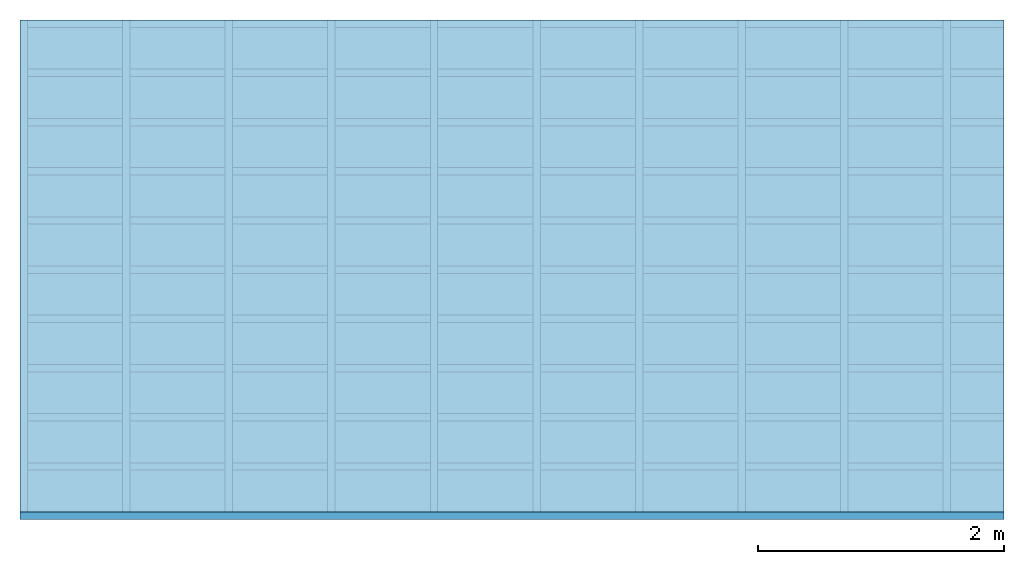
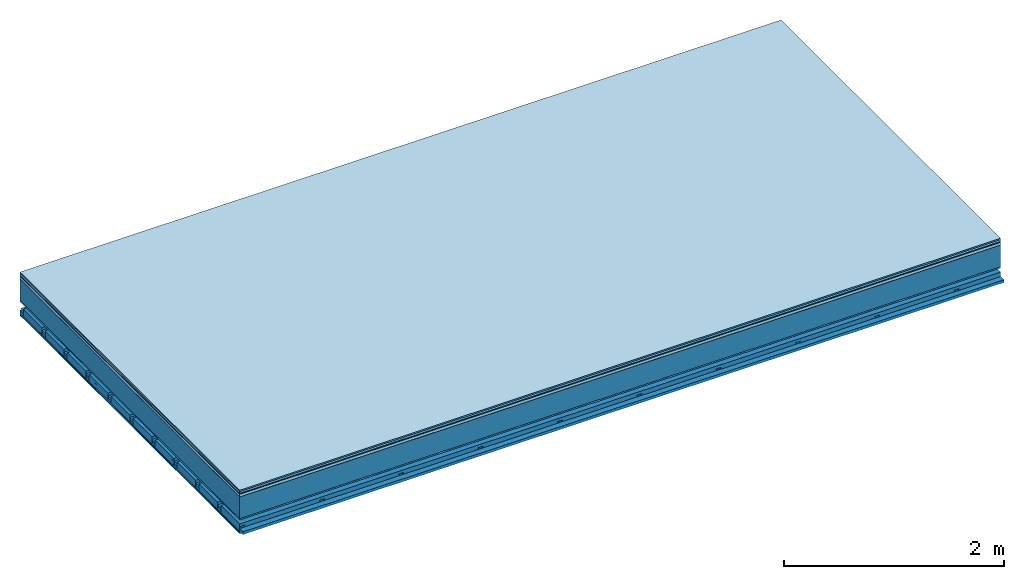
# One storey: 9 plates, 4 members, 1 element without a shape of its own.
"""IFC4 building model written with IfcOpenShell, lengths in metres."""

from ifc_helpers import new_model, si_unit, derived_unit, direction, frame, frame_2d, origin, origin_with_axes, place, context, project, spatial, polyline, rectangle, outline, extrude, material, layer, layer_set, type_object, element, aggregate, save


model = new_model("IFC4")

# Units and contexts
plan_context = context("Plan", 3, precision=1e-05, world=origin(), true_north=direction((0.0, 1.0)))
model_context = context("Model", 3, precision=1e-05, world=origin(), true_north=direction((0.0, 1.0)))
ifc_project = project(units=[si_unit("LENGTHUNIT", "METRE"), derived_unit("SOUNDPRESSUREUNIT", [(si_unit("PRESSUREUNIT", "PASCAL", prefix="MICRO"), 0)]), si_unit("ENERGYUNIT", "JOULE", prefix="MEGA"), si_unit("MASSUNIT", "GRAM", prefix="KILO"), derived_unit("THERMALTRANSMITTANCEUNIT", [(si_unit("POWERUNIT", "WATT"), 1), (si_unit("AREAUNIT", "SQUARE_METRE"), -1), (si_unit("THERMODYNAMICTEMPERATUREUNIT", "KELVIN"), -1)]), derived_unit("AREADENSITYUNIT", [(si_unit("MASSUNIT", "GRAM", prefix="KILO"), 1), (si_unit("AREAUNIT", "SQUARE_METRE"), -1)]), derived_unit("USERDEFINED", [(si_unit("ENERGYUNIT", "JOULE", prefix="MEGA"), 1), (si_unit("AREAUNIT", "SQUARE_METRE"), -1)])], contexts=[plan_context, model_context])

# Site, building, storey
site = spatial("IfcSite", under=ifc_project)
building_placement = place(None, origin())
building = spatial("IfcBuilding", under=site, at=building_placement)
storey_placement = place(building_placement, origin())
storey = spatial("IfcBuildingStorey", under=building, at=storey_placement)

# Slab, members, plates
ifc_material_1 = material(Category="11.013")
ifc_layer_1 = layer(ifc_material_1, 0.015, Name="Flooring")
ifc_material_2 = material(Category="03.007")
ifc_layer_2 = layer(ifc_material_2, 0.02, Name="On-material")
ifc_material_3 = material(Name="Wood fiber generic product", Category="10.009")
ifc_layer_3 = layer(ifc_material_3, 0.01, Name="Impact sound insulation")
ifc_material_4 = material(Name="with broken")
ifc_layer_4 = layer(ifc_material_4, 0.03, Name="on Supporting structure")
ifc_material_5 = material(Name="protection", Category="09.007")
ifc_layer_5 = layer(ifc_material_5, 0.0005, Name="Sub-floor")
ifc_material_6 = material(Name="no composite action")
ifc_layer_6 = layer(ifc_material_6, 0.0, Name="Bond")
ifc_layer_7 = layer(None, 0.24, Name="Supporting structure")
ifc_material_7 = material(Name="of the art")
ifc_layer_8 = layer(ifc_material_7, 0.0, Name="Bond")
ifc_layer_9 = layer(ifc_material_2, 0.015, Name="Lower layer 1")
ifc_layer_10 = layer(None, 0.095, Name="Coupling")
ifc_layer_11 = layer(None, 0.03, Name="Battens / profiles")
ifc_material_8 = material(Name="Plasterboard type A", Category="03.008")
ifc_layer_12 = layer(ifc_material_8, 0.0125, Name="Ceiling covering 1st layer")
ifc_layer_13 = layer(ifc_material_8, 0.0125, Name="Ceiling covering layer 2")
ifc_material_9 = material(Category="04.001")
ifc_layer_14 = layer(ifc_material_9, 0.003, Name="Surface / treatment")
ifc_layer_set = layer_set([ifc_layer_1, ifc_layer_2, ifc_layer_3, ifc_layer_4, ifc_layer_5, ifc_layer_6, ifc_layer_7, ifc_layer_8, ifc_layer_9, ifc_layer_10, ifc_layer_11, ifc_layer_12, ifc_layer_13, ifc_layer_14])
slab_type = type_object("IfcSlabType", Name="A2129", PredefinedType="NOTDEFINED", material=ifc_layer_set)
slab_placement = place(None, frame((0.0, 0.0, 0.0), z_axis=(0.0, 0.0, -1.0), x_axis=(1.0, 0.0, 0.0)))
slab = element("IfcSlab", 1, at=slab_placement, inside=storey, type_object=slab_type, material=ifc_layer_set, Name="Slab #1")
ifc_material_10 = material(Name="Solid timber panel")
member_1_placement = place(slab_placement, origin())
member_1 = element("IfcMember", 2, at=member_1_placement, material=ifc_material_10, Name="Supporting structure", context=plan_context, shape_type="SweptSolid", body=[
    extrude(rectangle(XDim=1.0, YDim=0.24, at=frame_2d((0.5, 0.12), x_axis=(1.0, 0.0))), frame((0.0, 4.0, 0.0755), z_axis=(0.0, -1.0, 0.0), x_axis=(1.0, 0.0, 0.0)), (0.0, 0.0, 1.0), 4.0),
    extrude(rectangle(XDim=1.0, YDim=0.24, at=frame_2d((0.5, 0.12), x_axis=(1.0, 0.0))), frame((1.0, 4.0, 0.0755), z_axis=(0.0, -1.0, 0.0), x_axis=(1.0, 0.0, 0.0)), (0.0, 0.0, 1.0), 4.0),
    extrude(rectangle(XDim=1.0, YDim=0.24, at=frame_2d((0.5, 0.12), x_axis=(1.0, 0.0))), frame((2.0, 4.0, 0.0755), z_axis=(0.0, -1.0, 0.0), x_axis=(1.0, 0.0, 0.0)), (0.0, 0.0, 1.0), 4.0),
    extrude(rectangle(XDim=1.0, YDim=0.24, at=frame_2d((0.5, 0.12), x_axis=(1.0, 0.0))), frame((3.0, 4.0, 0.0755), z_axis=(0.0, -1.0, 0.0), x_axis=(1.0, 0.0, 0.0)), (0.0, 0.0, 1.0), 4.0),
    extrude(rectangle(XDim=1.0, YDim=0.24, at=frame_2d((0.5, 0.12), x_axis=(1.0, 0.0))), frame((4.0, 4.0, 0.0755), z_axis=(0.0, -1.0, 0.0), x_axis=(1.0, 0.0, 0.0)), (0.0, 0.0, 1.0), 4.0),
    extrude(rectangle(XDim=1.0, YDim=0.24, at=frame_2d((0.5, 0.12), x_axis=(1.0, 0.0))), frame((5.0, 4.0, 0.0755), z_axis=(0.0, -1.0, 0.0), x_axis=(1.0, 0.0, 0.0)), (0.0, 0.0, 1.0), 4.0),
    extrude(rectangle(XDim=1.0, YDim=0.24, at=frame_2d((0.5, 0.12), x_axis=(1.0, 0.0))), frame((6.0, 4.0, 0.0755), z_axis=(0.0, -1.0, 0.0), x_axis=(1.0, 0.0, 0.0)), (0.0, 0.0, 1.0), 4.0),
    extrude(rectangle(XDim=1.0, YDim=0.24, at=frame_2d((0.5, 0.12), x_axis=(1.0, 0.0))), frame((7.0, 4.0, 0.0755), z_axis=(0.0, -1.0, 0.0), x_axis=(1.0, 0.0, 0.0)), (0.0, 0.0, 1.0), 4.0),
])
ifc_material_11 = material()
member_2_placement = place(slab_placement, origin())
member_2 = element("IfcMember", 3, at=member_2_placement, material=ifc_material_11, Name="Coupling", context=plan_context, shape_type="SweptSolid", body=[
    extrude(outline(polyline([(0.0, 0.0), (0.06, 0.0), (0.04, 0.02), (0.02, 0.02), (0.0, 0.0)])), frame((0.0, 4.0, 0.4055), z_axis=(0.0, -1.0, 0.0), x_axis=(1.0, 0.0, 0.0)), (0.0, 0.0, 1.0), 4.0),
    extrude(outline(polyline([(0.0, 0.0), (0.06, 0.0), (0.04, 0.02), (0.02, 0.02), (0.0, 0.0)])), frame((0.834, 4.0, 0.4055), z_axis=(0.0, -1.0, 0.0), x_axis=(1.0, 0.0, 0.0)), (0.0, 0.0, 1.0), 4.0),
    extrude(outline(polyline([(0.0, 0.0), (0.06, 0.0), (0.04, 0.02), (0.02, 0.02), (0.0, 0.0)])), frame((1.668, 4.0, 0.4055), z_axis=(0.0, -1.0, 0.0), x_axis=(1.0, 0.0, 0.0)), (0.0, 0.0, 1.0), 4.0),
    extrude(outline(polyline([(0.0, 0.0), (0.06, 0.0), (0.04, 0.02), (0.02, 0.02), (0.0, 0.0)])), frame((2.502, 4.0, 0.4055), z_axis=(0.0, -1.0, 0.0), x_axis=(1.0, 0.0, 0.0)), (0.0, 0.0, 1.0), 4.0),
    extrude(outline(polyline([(0.0, 0.0), (0.06, 0.0), (0.04, 0.02), (0.02, 0.02), (0.0, 0.0)])), frame((3.336, 4.0, 0.4055), z_axis=(0.0, -1.0, 0.0), x_axis=(1.0, 0.0, 0.0)), (0.0, 0.0, 1.0), 4.0),
    extrude(outline(polyline([(0.0, 0.0), (0.06, 0.0), (0.04, 0.02), (0.02, 0.02), (0.0, 0.0)])), frame((4.17, 4.0, 0.4055), z_axis=(0.0, -1.0, 0.0), x_axis=(1.0, 0.0, 0.0)), (0.0, 0.0, 1.0), 4.0),
    extrude(outline(polyline([(0.0, 0.0), (0.06, 0.0), (0.04, 0.02), (0.02, 0.02), (0.0, 0.0)])), frame((5.004, 4.0, 0.4055), z_axis=(0.0, -1.0, 0.0), x_axis=(1.0, 0.0, 0.0)), (0.0, 0.0, 1.0), 4.0),
    extrude(outline(polyline([(0.0, 0.0), (0.06, 0.0), (0.04, 0.02), (0.02, 0.02), (0.0, 0.0)])), frame((5.838, 4.0, 0.4055), z_axis=(0.0, -1.0, 0.0), x_axis=(1.0, 0.0, 0.0)), (0.0, 0.0, 1.0), 4.0),
    extrude(outline(polyline([(0.0, 0.0), (0.06, 0.0), (0.04, 0.02), (0.02, 0.02), (0.0, 0.0)])), frame((6.672, 4.0, 0.4055), z_axis=(0.0, -1.0, 0.0), x_axis=(1.0, 0.0, 0.0)), (0.0, 0.0, 1.0), 4.0),
    extrude(outline(polyline([(0.0, 0.0), (0.06, 0.0), (0.04, 0.02), (0.02, 0.02), (0.0, 0.0)])), frame((7.506, 4.0, 0.4055), z_axis=(0.0, -1.0, 0.0), x_axis=(1.0, 0.0, 0.0)), (0.0, 0.0, 1.0), 4.0),
])
member_3_placement = place(slab_placement, origin())
member_3 = element("IfcMember", 4, at=member_3_placement, material=ifc_material_11, Name="Battens / profiles", context=plan_context, shape_type="SweptSolid", body=[
    extrude(rectangle(XDim=0.06, YDim=0.03, at=frame_2d((0.03, 0.015), x_axis=(1.0, 0.0))), frame((0.0, 0.0, 0.4255), z_axis=(1.0, 0.0, 0.0), x_axis=(0.0, 1.0, 0.0)), (0.0, 0.0, 1.0), 8.0),
    extrude(rectangle(XDim=0.06, YDim=0.03, at=frame_2d((0.03, 0.015), x_axis=(1.0, 0.0))), frame((0.0, 0.4, 0.4255), z_axis=(1.0, 0.0, 0.0), x_axis=(0.0, 1.0, 0.0)), (0.0, 0.0, 1.0), 8.0),
    extrude(rectangle(XDim=0.06, YDim=0.03, at=frame_2d((0.03, 0.015), x_axis=(1.0, 0.0))), frame((0.0, 0.8, 0.4255), z_axis=(1.0, 0.0, 0.0), x_axis=(0.0, 1.0, 0.0)), (0.0, 0.0, 1.0), 8.0),
    extrude(rectangle(XDim=0.06, YDim=0.03, at=frame_2d((0.03, 0.015), x_axis=(1.0, 0.0))), frame((0.0, 1.2, 0.4255), z_axis=(1.0, 0.0, 0.0), x_axis=(0.0, 1.0, 0.0)), (0.0, 0.0, 1.0), 8.0),
    extrude(rectangle(XDim=0.06, YDim=0.03, at=frame_2d((0.03, 0.015), x_axis=(1.0, 0.0))), frame((0.0, 1.6, 0.4255), z_axis=(1.0, 0.0, 0.0), x_axis=(0.0, 1.0, 0.0)), (0.0, 0.0, 1.0), 8.0),
    extrude(rectangle(XDim=0.06, YDim=0.03, at=frame_2d((0.03, 0.015), x_axis=(1.0, 0.0))), frame((0.0, 2.0, 0.4255), z_axis=(1.0, 0.0, 0.0), x_axis=(0.0, 1.0, 0.0)), (0.0, 0.0, 1.0), 8.0),
    extrude(rectangle(XDim=0.06, YDim=0.03, at=frame_2d((0.03, 0.015), x_axis=(1.0, 0.0))), frame((0.0, 2.4, 0.4255), z_axis=(1.0, 0.0, 0.0), x_axis=(0.0, 1.0, 0.0)), (0.0, 0.0, 1.0), 8.0),
    extrude(rectangle(XDim=0.06, YDim=0.03, at=frame_2d((0.03, 0.015), x_axis=(1.0, 0.0))), frame((0.0, 2.8, 0.4255), z_axis=(1.0, 0.0, 0.0), x_axis=(0.0, 1.0, 0.0)), (0.0, 0.0, 1.0), 8.0),
    extrude(rectangle(XDim=0.06, YDim=0.03, at=frame_2d((0.03, 0.015), x_axis=(1.0, 0.0))), frame((0.0, 3.2, 0.4255), z_axis=(1.0, 0.0, 0.0), x_axis=(0.0, 1.0, 0.0)), (0.0, 0.0, 1.0), 8.0),
    extrude(rectangle(XDim=0.06, YDim=0.03, at=frame_2d((0.03, 0.015), x_axis=(1.0, 0.0))), frame((0.0, 3.6, 0.4255), z_axis=(1.0, 0.0, 0.0), x_axis=(0.0, 1.0, 0.0)), (0.0, 0.0, 1.0), 8.0),
    extrude(rectangle(XDim=0.06, YDim=0.03, at=frame_2d((0.03, 0.015), x_axis=(1.0, 0.0))), frame((0.0, 4.0, 0.4255), z_axis=(1.0, 0.0, 0.0), x_axis=(0.0, 1.0, 0.0)), (0.0, 0.0, 1.0), 8.0),
])
ifc_material_12 = material()
member_4_placement = place(slab_placement, origin())
member_4 = element("IfcMember", 5, at=member_4_placement, material=ifc_material_12, Name="Cavity", context=plan_context, shape_type="SweptSolid", body=[
    extrude(rectangle(XDim=0.34, YDim=0.08, at=frame_2d((0.17, 0.04), x_axis=(1.0, 0.0))), frame((0.0, 0.06, 0.3755), z_axis=(1.0, 0.0, 0.0), x_axis=(0.0, 1.0, 0.0)), (0.0, 0.0, 1.0), 8.0),
    extrude(rectangle(XDim=0.34, YDim=0.08, at=frame_2d((0.17, 0.04), x_axis=(1.0, 0.0))), frame((0.0, 0.46, 0.3755), z_axis=(1.0, 0.0, 0.0), x_axis=(0.0, 1.0, 0.0)), (0.0, 0.0, 1.0), 8.0),
    extrude(rectangle(XDim=0.34, YDim=0.08, at=frame_2d((0.17, 0.04), x_axis=(1.0, 0.0))), frame((0.0, 0.86, 0.3755), z_axis=(1.0, 0.0, 0.0), x_axis=(0.0, 1.0, 0.0)), (0.0, 0.0, 1.0), 8.0),
    extrude(rectangle(XDim=0.34, YDim=0.08, at=frame_2d((0.17, 0.04), x_axis=(1.0, 0.0))), frame((0.0, 1.26, 0.3755), z_axis=(1.0, 0.0, 0.0), x_axis=(0.0, 1.0, 0.0)), (0.0, 0.0, 1.0), 8.0),
    extrude(rectangle(XDim=0.34, YDim=0.08, at=frame_2d((0.17, 0.04), x_axis=(1.0, 0.0))), frame((0.0, 1.66, 0.3755), z_axis=(1.0, 0.0, 0.0), x_axis=(0.0, 1.0, 0.0)), (0.0, 0.0, 1.0), 8.0),
    extrude(rectangle(XDim=0.34, YDim=0.08, at=frame_2d((0.17, 0.04), x_axis=(1.0, 0.0))), frame((0.0, 2.06, 0.3755), z_axis=(1.0, 0.0, 0.0), x_axis=(0.0, 1.0, 0.0)), (0.0, 0.0, 1.0), 8.0),
    extrude(rectangle(XDim=0.34, YDim=0.08, at=frame_2d((0.17, 0.04), x_axis=(1.0, 0.0))), frame((0.0, 2.46, 0.3755), z_axis=(1.0, 0.0, 0.0), x_axis=(0.0, 1.0, 0.0)), (0.0, 0.0, 1.0), 8.0),
    extrude(rectangle(XDim=0.34, YDim=0.08, at=frame_2d((0.17, 0.04), x_axis=(1.0, 0.0))), frame((0.0, 2.86, 0.3755), z_axis=(1.0, 0.0, 0.0), x_axis=(0.0, 1.0, 0.0)), (0.0, 0.0, 1.0), 8.0),
    extrude(rectangle(XDim=0.34, YDim=0.08, at=frame_2d((0.17, 0.04), x_axis=(1.0, 0.0))), frame((0.0, 3.26, 0.3755), z_axis=(1.0, 0.0, 0.0), x_axis=(0.0, 1.0, 0.0)), (0.0, 0.0, 1.0), 8.0),
    extrude(rectangle(XDim=0.34, YDim=0.08, at=frame_2d((0.17, 0.04), x_axis=(1.0, 0.0))), frame((0.0, 3.66, 0.3755), z_axis=(1.0, 0.0, 0.0), x_axis=(0.0, 1.0, 0.0)), (0.0, 0.0, 1.0), 8.0),
])
plate_1_placement = place(slab_placement, origin())
plate_1 = element("IfcPlate", 6, at=plate_1_placement, material=ifc_material_1, Name="Flooring", context=plan_context, shape_type="SweptSolid", body=[
    extrude(rectangle(XDim=8.0, YDim=4.0, at=frame_2d((4.0, 2.0), x_axis=(1.0, 0.0))), origin_with_axes(), (0.0, 0.0, 1.0), 0.015),
])
plate_2_placement = place(slab_placement, origin())
plate_2 = element("IfcPlate", 7, at=plate_2_placement, material=ifc_material_2, Name="On-material", context=plan_context, shape_type="SweptSolid", body=[
    extrude(rectangle(XDim=8.0, YDim=4.0, at=frame_2d((4.0, 2.0), x_axis=(1.0, 0.0))), frame((0.0, 0.0, 0.015), z_axis=(0.0, 0.0, 1.0), x_axis=(1.0, 0.0, 0.0)), (0.0, 0.0, 1.0), 0.02),
])
plate_3_placement = place(slab_placement, origin())
plate_3 = element("IfcPlate", 8, at=plate_3_placement, material=ifc_material_3, Name="Impact sound insulation", context=plan_context, shape_type="SweptSolid", body=[
    extrude(rectangle(XDim=8.0, YDim=4.0, at=frame_2d((4.0, 2.0), x_axis=(1.0, 0.0))), frame((0.0, 0.0, 0.035), z_axis=(0.0, 0.0, 1.0), x_axis=(1.0, 0.0, 0.0)), (0.0, 0.0, 1.0), 0.01),
])
plate_4_placement = place(slab_placement, origin())
plate_4 = element("IfcPlate", 9, at=plate_4_placement, material=ifc_material_4, Name="on Supporting structure", context=plan_context, shape_type="SweptSolid", body=[
    extrude(rectangle(XDim=8.0, YDim=4.0, at=frame_2d((4.0, 2.0), x_axis=(1.0, 0.0))), frame((0.0, 0.0, 0.045), z_axis=(0.0, 0.0, 1.0), x_axis=(1.0, 0.0, 0.0)), (0.0, 0.0, 1.0), 0.03),
])
plate_5_placement = place(slab_placement, origin())
plate_5 = element("IfcPlate", 10, at=plate_5_placement, material=ifc_material_5, Name="Sub-floor", context=plan_context, shape_type="SweptSolid", body=[
    extrude(rectangle(XDim=8.0, YDim=4.0, at=frame_2d((4.0, 2.0), x_axis=(1.0, 0.0))), frame((0.0, 0.0, 0.075), z_axis=(0.0, 0.0, 1.0), x_axis=(1.0, 0.0, 0.0)), (0.0, 0.0, 1.0), 0.0005),
])
plate_6_placement = place(slab_placement, origin())
plate_6 = element("IfcPlate", 11, at=plate_6_placement, material=ifc_material_2, Name="Lower layer 1", context=plan_context, shape_type="SweptSolid", body=[
    extrude(rectangle(XDim=8.0, YDim=4.0, at=frame_2d((4.0, 2.0), x_axis=(1.0, 0.0))), frame((0.0, 0.0, 0.3155), z_axis=(0.0, 0.0, 1.0), x_axis=(1.0, 0.0, 0.0)), (0.0, 0.0, 1.0), 0.015),
])
plate_7_placement = place(slab_placement, origin())
plate_7 = element("IfcPlate", 12, at=plate_7_placement, material=ifc_material_8, Name="Ceiling covering 1st layer", context=plan_context, shape_type="SweptSolid", body=[
    extrude(rectangle(XDim=8.0, YDim=4.0, at=frame_2d((4.0, 2.0), x_axis=(1.0, 0.0))), frame((0.0, 0.0, 0.4555), z_axis=(0.0, 0.0, 1.0), x_axis=(1.0, 0.0, 0.0)), (0.0, 0.0, 1.0), 0.0125),
])
plate_8_placement = place(slab_placement, origin())
plate_8 = element("IfcPlate", 13, at=plate_8_placement, material=ifc_material_8, Name="Ceiling covering layer 2", context=plan_context, shape_type="SweptSolid", body=[
    extrude(rectangle(XDim=8.0, YDim=4.0, at=frame_2d((4.0, 2.0), x_axis=(1.0, 0.0))), frame((0.0, 0.0, 0.468), z_axis=(0.0, 0.0, 1.0), x_axis=(1.0, 0.0, 0.0)), (0.0, 0.0, 1.0), 0.0125),
])
plate_9_placement = place(slab_placement, origin())
plate_9 = element("IfcPlate", 14, at=plate_9_placement, material=ifc_material_9, Name="Surface / treatment", context=plan_context, shape_type="SweptSolid", body=[
    extrude(rectangle(XDim=8.0, YDim=4.0, at=frame_2d((4.0, 2.0), x_axis=(1.0, 0.0))), frame((0.0, 0.0, 0.4805), z_axis=(0.0, 0.0, 1.0), x_axis=(1.0, 0.0, 0.0)), (0.0, 0.0, 1.0), 0.003),
])
aggregate(slab, [plate_1, plate_2, plate_3, plate_4, plate_5, member_1, plate_6, member_2, member_3, member_4, plate_7, plate_8, plate_9])

save(model, "model.ifc")
